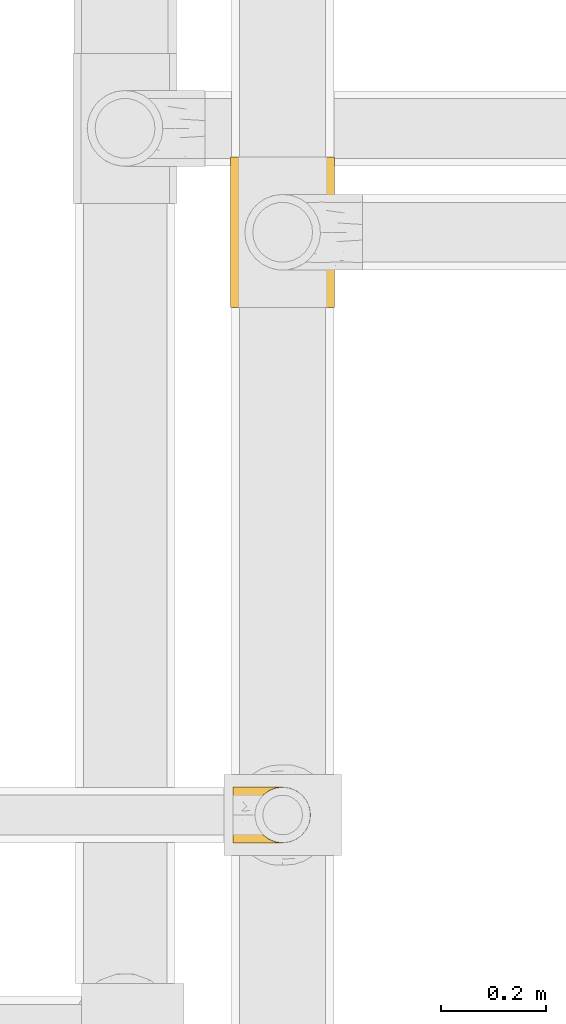
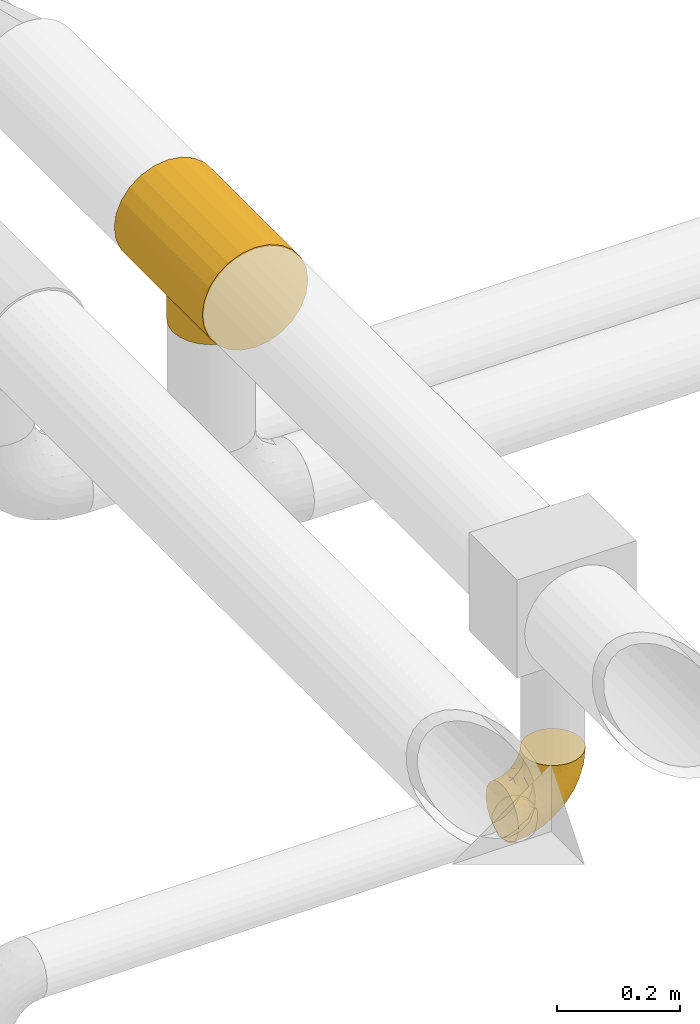
# One storey, part 234 of 827: 2 coverings.
"""IFC2X3 building model written with IfcOpenShell, lengths in millimetres."""

import ifcopenshell
import ifcopenshell.guid

model = None  # the IFC model being written
_history = None  # IfcOwnerHistory: only IFC2X3 demands one
_inside = {}  # id of a spatial element -> (the spatial element, [elements in it])
_under = {}  # id of a project, library or spatial element -> (it, [spatial elements below it])
_declared = {}  # id of a project -> (the project, [libraries it declares])
_typed = {}  # id of a type object -> (the type object, [elements of that type])
_made_of = {}  # id of a material, layer set ... -> (it, [elements and type objects made of it])


def new_model(schema):
    """Start an empty IFC model of exactly this schema.

    Asked for "IFC4X3", IfcOpenShell would pick the latest addendum, in which some entities
    have other attributes; the version numbers below select the first issue.
    IFC2X3 requires an IfcOwnerHistory on every rooted entity: one is made here for all.
    """
    global model, _history
    if schema == "IFC4X3":
        model = ifcopenshell.file(schema_version=(4, 3, 0, 0))
    else:
        model = ifcopenshell.file(schema=schema)
    _inside.clear()
    _under.clear()
    _declared.clear()
    _typed.clear()
    _made_of.clear()
    _history = None
    if model.schema == "IFC2X3":
        org = make("IfcOrganization", Name="unknown")
        user = make(
            "IfcPersonAndOrganization",
            ThePerson=make("IfcPerson", FamilyName="unknown"),
            TheOrganization=org,
        )
        app = make(
            "IfcApplication",
            ApplicationDeveloper=org,
            Version="unknown",
            ApplicationFullName="unknown",
            ApplicationIdentifier="unknown",
        )
        _history = make(
            "IfcOwnerHistory",
            OwningUser=user,
            OwningApplication=app,
            ChangeAction="ADDED",
            CreationDate=0,
        )
    return model


def make(cls, **values):
    """One entity of the class cls with the attributes given. An attribute that is None is left unset."""
    return model.create_entity(
        cls, **{name: value for name, value in values.items() if value is not None}
    )


def entity(cls, *values):
    """Any entity or typed value of the class cls, its attributes in the order of the schema. None: left unset."""
    e = model.create_entity(cls)
    for i, value in enumerate(values):
        if value is not None:
            e[i] = value
    return e


def rooted(cls, **values):
    """An entity with a GlobalId (a new one), such as an element, a storey or a relation."""
    return make(cls, GlobalId=ifcopenshell.guid.new(), OwnerHistory=_history, **values)


def si_unit(unit_type, name, prefix=None):
    """IfcSIUnit, for example si_unit("LENGTHUNIT", "METRE", prefix="MILLI")."""
    return make("IfcSIUnit", UnitType=unit_type, Prefix=prefix, Name=name)


def converted_unit(unit_type, name, factor, base, dimensions=None, offset=None):
    """IfcConversionBasedUnit, such as the inch: factor (a typed value) times the base unit."""
    return make(
        "IfcConversionBasedUnit"
        if offset is None
        else "IfcConversionBasedUnitWithOffset",
        ConversionOffset=offset,
        Dimensions=None
        if dimensions is None
        else entity("IfcDimensionalExponents", *dimensions),
        UnitType=unit_type,
        Name=name,
        ConversionFactor=make(
            "IfcMeasureWithUnit", ValueComponent=factor, UnitComponent=base
        ),
    )


def derived_unit(unit_type, elements):
    """IfcDerivedUnit: a product of units, each with its exponent."""
    return make(
        "IfcDerivedUnit",
        Elements=[
            make("IfcDerivedUnitElement", Unit=unit, Exponent=power)
            for unit, power in elements
        ],
        UnitType=unit_type,
    )


def assignment(units):
    """IfcUnitAssignment: the units of a project."""
    return None if units is None else make("IfcUnitAssignment", Units=units)


def point(xyz):
    """IfcCartesianPoint."""
    return None if xyz is None else make("IfcCartesianPoint", Coordinates=xyz)


def direction(xyz):
    """IfcDirection."""
    return None if xyz is None else make("IfcDirection", DirectionRatios=xyz)


def frame(location, z_axis=None, x_axis=None):
    """IfcAxis2Placement3D, a coordinate frame: its origin and axes. An axis left out is left unset."""
    return make(
        "IfcAxis2Placement3D",
        Location=point(location),
        Axis=direction(z_axis),
        RefDirection=direction(x_axis),
    )


def origin():
    """The frame at (0, 0, 0) with its axes left unset."""
    return frame((0.0, 0.0, 0.0))


def place(relative_to, where):
    """IfcLocalPlacement: puts the frame where relative to a parent placement (None: the world)."""
    return make(
        "IfcLocalPlacement", PlacementRelTo=relative_to, RelativePlacement=where
    )


def context(
    kind, dimensions, precision=None, world=None, true_north=None, identifier=None
):
    """IfcGeometricRepresentationContext, for example the 3D "Model" context."""
    return make(
        "IfcGeometricRepresentationContext",
        ContextIdentifier=identifier,
        ContextType=kind,
        CoordinateSpaceDimension=dimensions,
        Precision=precision,
        WorldCoordinateSystem=world,
        TrueNorth=true_north,
    )


def subcontext(parent, identifier, kind, view, scale=None):
    """IfcGeometricRepresentationSubContext, for example "Body" below "Model"."""
    return make(
        "IfcGeometricRepresentationSubContext",
        ContextIdentifier=identifier,
        ContextType=kind,
        ParentContext=parent,
        TargetScale=scale,
        TargetView=view,
    )


def project(units=None, contexts=None):
    """IfcProject with its units and contexts."""
    return rooted(
        "IfcProject",
        Name="project",
        RepresentationContexts=contexts,
        UnitsInContext=assignment(units),
    )


def spatial(cls, under=None, at=None, **own):
    """A site, building, storey or space (cls), placed at a placement, below another one or the project."""
    s = rooted(cls, ObjectPlacement=at, **own)
    if under is not None:
        _under.setdefault(under.id(), (under, []))[1].append(s)
    return s


def faces_of(points, faces, orient=None, outer=None):
    """IfcFace entities. A face is a list of loops; a loop is a list of indices into points, from 0.

    orient and outer hold one flag for each loop. By default every Orientation is true, the
    first loop of a face is its IfcFaceOuterBound and the others are IfcFaceBound.
    """
    made = []
    for i, loops in enumerate(faces):
        bounds = []
        for j, loop in enumerate(loops):
            is_outer = j == 0 if outer is None else outer[i][j]
            bounds.append(
                make(
                    "IfcFaceOuterBound" if is_outer else "IfcFaceBound",
                    Bound=make("IfcPolyLoop", Polygon=[points[k] for k in loop]),
                    Orientation=True if orient is None else orient[i][j],
                )
            )
        made.append(make("IfcFace", Bounds=bounds))
    return made


def faceted_brep(points, faces, orient=None, outer=None, voids=None):
    """IfcFacetedBrep: a solid bounded by flat faces; with voids (closed shells), ...WithVoids."""
    shared = [point(p) for p in points]
    hull = make("IfcClosedShell", CfsFaces=faces_of(shared, faces, orient, outer))
    if voids is None:
        return make("IfcFacetedBrep", Outer=hull)
    return make(
        "IfcFacetedBrepWithVoids",
        Outer=hull,
        Voids=[
            make(cls, CfsFaces=faces_of(shared, fs, o, b)) for cls, fs, o, b in voids
        ],
    )


def shape(context_of_items, identifier, shape_type, items):
    """IfcShapeRepresentation: the items that make up one representation, for example the "Body"."""
    return make(
        "IfcShapeRepresentation",
        ContextOfItems=context_of_items,
        RepresentationIdentifier=identifier,
        RepresentationType=shape_type,
        Items=items,
    )


def made_of(thing, what):
    """Note that an element or type object is made of a material, layer set ...; save() writes the relation."""
    if what is not None:
        _made_of.setdefault(what.id(), (what, []))[1].append(thing)
    return thing


def element(
    cls,
    number,
    at=None,
    inside=None,
    cuts=None,
    type_object=None,
    material=None,
    context=None,
    identifier="Body",
    shape_type=None,
    held_by="IfcProductDefinitionShape",
    body=None,
    shapes=None,
    **own,
):
    """One element of the class cls, such as IfcWall. Its Tag is "e" and its number.

    at: its placement. inside: the storey or other place that contains it. cuts: it is an
    opening in that element (IfcRelVoidsElement). A single representation is given by context,
    identifier, shape_type and body (its items); several are given by shapes. held_by: the class
    of the entity that holds the representations. save() writes the other relations.
    """
    e = rooted(cls, Tag="e%d" % number, ObjectPlacement=at, **own)
    if body is not None:
        shapes = [shape(context, identifier, shape_type, body)]
    if shapes is not None:
        e.Representation = make(held_by, Representations=shapes)
    if inside is not None:
        _inside.setdefault(inside.id(), (inside, []))[1].append(e)
    if cuts is not None:
        rooted(
            "IfcRelVoidsElement", RelatingBuildingElement=cuts, RelatedOpeningElement=e
        )
    if type_object is not None:
        _typed.setdefault(type_object.id(), (type_object, []))[1].append(e)
    return made_of(e, material)


def aggregate(whole, parts):
    """IfcRelAggregates: a whole, such as a stair, and the parts it consists of."""
    return rooted("IfcRelAggregates", RelatingObject=whole, RelatedObjects=parts)


def save(model, path):
    """Write the relations noted so far, then the file.

    IfcRelAggregates (storeys below a building ...), IfcRelContainedInSpatialStructure (elements
    in a storey), IfcRelDefinesByType, IfcRelAssociatesMaterial and IfcRelDeclares: one each for
    every whole, place, type object, material and project.
    """
    for whole, parts in _under.values():
        aggregate(whole, parts)
    for where, things in _inside.values():
        rooted(
            "IfcRelContainedInSpatialStructure",
            RelatedElements=things,
            RelatingStructure=where,
        )
    for kind, things in _typed.values():
        rooted("IfcRelDefinesByType", RelatedObjects=things, RelatingType=kind)
    for what, things in _made_of.values():
        rooted("IfcRelAssociatesMaterial", RelatedObjects=things, RelatingMaterial=what)
    for by, libraries in _declared.values():
        rooted("IfcRelDeclares", RelatingContext=by, RelatedDefinitions=libraries)
    model.write(path)


model = new_model("IFC2X3")

# Units and contexts
model_context = context("Model", 3, precision=0.01, world=origin(), true_north=direction((6.12303176911189e-17, 1.0)))
body_context = subcontext(model_context, "Body", "Model", "MODEL_VIEW")
ifc_project = project(units=[si_unit("LENGTHUNIT", "METRE", prefix="MILLI"), si_unit("AREAUNIT", "SQUARE_METRE"), si_unit("VOLUMEUNIT", "CUBIC_METRE"), converted_unit("PLANEANGLEUNIT", "DEGREE", entity("IfcRatioMeasure", 0.0174532925199433), si_unit("PLANEANGLEUNIT", "RADIAN"), dimensions=[0, 0, 0, 0, 0, 0, 0]), si_unit("MASSUNIT", "GRAM", prefix="KILO"), derived_unit("MASSDENSITYUNIT", [(si_unit("MASSUNIT", "GRAM", prefix="KILO"), 1), (si_unit("LENGTHUNIT", "METRE"), -3)]), derived_unit("MOMENTOFINERTIAUNIT", [(si_unit("LENGTHUNIT", "METRE"), 4)]), si_unit("TIMEUNIT", "SECOND"), si_unit("FREQUENCYUNIT", "HERTZ"), si_unit("THERMODYNAMICTEMPERATUREUNIT", "DEGREE_CELSIUS"), derived_unit("THERMALTRANSMITTANCEUNIT", [(si_unit("MASSUNIT", "GRAM", prefix="KILO"), 1), (si_unit("THERMODYNAMICTEMPERATUREUNIT", "KELVIN"), -1), (si_unit("TIMEUNIT", "SECOND"), -3)]), derived_unit("VOLUMETRICFLOWRATEUNIT", [(si_unit("LENGTHUNIT", "METRE"), 3), (si_unit("TIMEUNIT", "SECOND"), -1)]), derived_unit("MASSFLOWRATEUNIT", [(si_unit("MASSUNIT", "GRAM", prefix="KILO"), 1), (si_unit("TIMEUNIT", "SECOND"), -1)]), derived_unit("ROTATIONALFREQUENCYUNIT", [(si_unit("TIMEUNIT", "SECOND"), -1)]), si_unit("ELECTRICCURRENTUNIT", "AMPERE"), si_unit("ELECTRICVOLTAGEUNIT", "VOLT"), si_unit("POWERUNIT", "WATT"), si_unit("FORCEUNIT", "NEWTON", prefix="KILO"), si_unit("ILLUMINANCEUNIT", "LUX"), si_unit("LUMINOUSFLUXUNIT", "LUMEN"), si_unit("LUMINOUSINTENSITYUNIT", "CANDELA"), derived_unit("USERDEFINED", [(si_unit("MASSUNIT", "GRAM", prefix="KILO"), -1), (si_unit("LENGTHUNIT", "METRE"), -2), (si_unit("TIMEUNIT", "SECOND"), 3), (si_unit("LUMINOUSFLUXUNIT", "LUMEN"), 1)]), derived_unit("LINEARVELOCITYUNIT", [(si_unit("LENGTHUNIT", "METRE"), 1), (si_unit("TIMEUNIT", "SECOND"), -1)]), si_unit("PRESSUREUNIT", "PASCAL"), derived_unit("USERDEFINED", [(si_unit("LENGTHUNIT", "METRE"), -2), (si_unit("MASSUNIT", "GRAM", prefix="KILO"), 1), (si_unit("TIMEUNIT", "SECOND"), -2)]), derived_unit("LINEARFORCEUNIT", [(si_unit("MASSUNIT", "GRAM", prefix="KILO"), 1), (si_unit("LENGTHUNIT", "METRE"), 1), (si_unit("TIMEUNIT", "SECOND"), -2), (si_unit("LENGTHUNIT", "METRE"), -1)]), derived_unit("PLANARFORCEUNIT", [(si_unit("MASSUNIT", "GRAM", prefix="KILO"), 1), (si_unit("LENGTHUNIT", "METRE"), 1), (si_unit("TIMEUNIT", "SECOND"), -2), (si_unit("LENGTHUNIT", "METRE"), -2)])], contexts=[model_context])

# Site, building, storey
site_placement = place(None, origin())
site = spatial("IfcSite", under=ifc_project, at=site_placement, CompositionType="ELEMENT")
building_placement = place(site_placement, origin())
building = spatial("IfcBuilding", under=site, at=building_placement, CompositionType="ELEMENT")
storey_placement = place(building_placement, frame((0.0, 0.0, 28200.0)))
storey = spatial("IfcBuildingStorey", under=building, at=storey_placement, Name="08", CompositionType="ELEMENT", Elevation=28200.0)

# Coverings
covering_1_placement = place(storey_placement, frame((37951.7, 12925.0, 2545.35)))
element("IfcCovering", 1, at=covering_1_placement, inside=storey, Name=":ADSK_", ObjectType=":ADSK_", PredefinedType="INSULATION", context=body_context, shape_type="Brep", body=[
    faceted_brep([(1.6, 66.44, 2.92), (1.6, 54.65, 1.6), (1.6, 42.84, 2.93), (1.6, 31.62, 6.85), (1.6, 21.56, 13.18), (1.6, 13.16, 21.58), (1.6, 6.84, 31.64), (1.6, 2.92, 42.85), (1.6, 1.6, 54.65), (1.6, 2.93, 66.46), (1.6, 6.85, 77.67), (1.6, 13.18, 87.73), (1.6, 21.58, 96.13), (1.6, 31.64, 102.45), (1.6, 42.85, 106.37), (1.6, 54.65, 107.7), (1.6, 66.46, 106.36), (1.6, 77.67, 102.44), (1.6, 87.73, 96.11), (1.6, 96.13, 87.71), (1.6, 102.45, 77.65), (1.6, 106.37, 66.44), (1.6, 107.7, 54.65), (1.6, 106.36, 42.84), (1.6, 102.44, 31.62), (1.6, 96.11, 21.56), (1.6, 87.71, 13.16), (1.6, 77.65, 6.84), (45.35, 40.91, 149.65), (50.65, 28.12, 149.65), (59.08, 17.13, 149.65), (70.07, 8.7, 149.65), (82.86, 3.4, 149.65), (96.6, 1.6, 149.65), (110.33, 3.4, 149.65), (123.12, 8.7, 149.65), (134.11, 17.13, 149.65), (142.54, 28.12, 149.65), (147.84, 40.91, 149.65), (149.65, 54.65, 149.65), (147.84, 68.38, 149.65), (142.54, 81.17, 149.65), (134.11, 92.16, 149.65), (123.12, 100.59, 149.65), (110.33, 105.89, 149.65), (96.6, 107.7, 149.65), (82.86, 105.89, 149.65), (70.07, 100.59, 149.65), (59.08, 92.16, 149.65), (50.65, 81.17, 149.65), (45.35, 68.38, 149.65), (43.55, 54.65, 149.65), (137.19, 85.53, 123.27), (141.79, 73.42, 114.15), (128.89, 83.77, 92.97), (146.54, 64.22, 124.11), (144.6, 54.65, 111.33), (69.77, 96.72, 42.13), (94.41, 93.36, 56.83), (87.22, 84.47, 40.31), (117.2, 71.37, 61.55), (129.81, 54.65, 75.62), (106.28, 54.65, 44.96), (101.45, 103.47, 91.12), (115.81, 100.91, 109.83), (109.14, 99.1, 88.02), (107.65, 105.43, 119.19), (93.36, 106.79, 99.11), (59.44, 89.81, 27.97), (63.23, 79.59, 21.92), (35.59, 81.29, 12.94), (132.3, 74.01, 88.29), (138.41, 64.14, 95.35), (126.28, 94.75, 113.84), (39.91, 54.65, 6.64), (37.44, 70.74, 8.58), (90.35, 68.3, 33.39), (65.0, 66.05, 17.23), (85.4, 100.73, 61.99), (26.66, 106.78, 47.9), (29.88, 103.6, 37.72), (78.45, 107.7, 93.81), (85.2, 107.7, 107.05), (91.95, 107.7, 120.29), (77.98, 106.07, 73.26), (29.55, 90.59, 18.58), (41.42, 97.43, 29.72), (111.13, 84.51, 64.31), (114.67, 93.3, 82.84), (57.43, 107.7, 72.79), (67.94, 107.7, 83.3), (14.64, 107.7, 56.71), (30.95, 107.7, 59.29), (52.13, 106.79, 57.88), (44.19, 107.7, 66.04), (60.12, 103.47, 49.8), (75.62, 54.65, 21.43), (94.27, 107.7, 134.97), (24.59, 76.99, 108.79), (34.69, 84.28, 110.84), (31.15, 91.11, 101.53), (75.18, 106.26, 111.84), (67.55, 102.6, 119.98), (79.36, 106.08, 123.54), (84.32, 106.56, 134.54), (40.81, 105.36, 80.57), (29.93, 106.74, 69.55), (70.24, 101.59, 134.56), (37.93, 54.65, 128.67), (40.15, 54.65, 136.98), (42.1, 67.71, 133.56), (55.38, 91.36, 131.66), (52.17, 94.33, 117.75), (44.32, 87.1, 118.23), (19.85, 65.84, 110.55), (14.26, 54.65, 111.09), (22.57, 54.65, 113.32), (34.17, 68.92, 120.2), (54.85, 100.82, 105.95), (44.63, 79.83, 127.69), (47.52, 77.13, 139.88), (59.1, 105.9, 92.14), (44.11, 101.53, 93.82), (53.21, 106.72, 82.28), (62.86, 97.75, 130.86), (20.58, 103.08, 78.78), (15.79, 106.39, 67.58), (27.67, 98.1, 90.58), (13.49, 95.02, 90.23), (18.04, 86.9, 99.39), (12.44, 74.42, 105.17), (30.25, 54.65, 120.99), (66.71, 105.28, 104.59), (42.52, 92.87, 108.24), (55.38, 17.93, 131.66), (20.57, 6.22, 78.8), (42.11, 41.58, 133.57), (57.43, 1.6, 72.79), (53.22, 2.57, 82.27), (40.81, 3.94, 80.59), (19.85, 43.46, 110.55), (24.58, 32.32, 108.79), (34.16, 40.38, 120.2), (42.5, 16.44, 108.25), (54.93, 8.47, 106.06), (52.13, 15.01, 117.78), (27.66, 11.21, 90.6), (44.12, 7.78, 93.87), (78.45, 1.6, 93.81), (85.2, 1.6, 107.05), (75.17, 3.04, 111.89), (94.27, 1.6, 134.97), (84.32, 2.73, 134.54), (30.95, 1.6, 59.29), (44.19, 1.6, 66.04), (29.98, 2.55, 69.56), (66.78, 3.98, 104.56), (67.55, 6.69, 119.98), (70.24, 7.7, 134.56), (79.36, 3.21, 123.54), (13.48, 14.28, 90.25), (18.03, 22.42, 99.4), (34.66, 25.02, 110.83), (31.14, 18.18, 101.52), (12.43, 34.89, 105.18), (14.64, 1.6, 56.71), (47.52, 32.17, 139.89), (44.28, 22.23, 118.22), (15.8, 2.91, 67.6), (62.86, 11.54, 130.86), (67.94, 1.6, 83.3), (59.12, 3.38, 92.12), (44.64, 29.46, 127.71), (91.95, 1.6, 120.29), (128.89, 25.52, 92.97), (137.19, 23.76, 123.27), (126.28, 14.54, 113.84), (115.81, 8.38, 109.83), (146.53, 45.07, 124.03), (141.79, 35.87, 114.15), (139.45, 45.14, 98.04), (93.36, 2.5, 99.11), (26.67, 2.51, 47.9), (29.87, 5.68, 37.74), (60.12, 5.82, 49.8), (94.41, 15.93, 56.83), (69.76, 12.54, 42.16), (87.19, 24.81, 40.3), (52.13, 2.5, 57.88), (77.98, 3.22, 73.26), (107.65, 3.86, 119.19), (131.74, 35.85, 86.61), (59.44, 19.47, 27.99), (29.54, 18.68, 18.59), (63.2, 29.68, 21.92), (27.9, 27.95, 11.28), (90.35, 40.99, 33.39), (117.2, 37.92, 61.55), (41.39, 11.85, 29.73), (109.14, 10.19, 88.01), (85.46, 8.55, 62.08), (37.43, 38.53, 8.58), (114.67, 15.99, 82.84), (111.12, 24.79, 64.3), (101.45, 5.82, 91.12), (65.16, 40.56, 18.05)], [[[0, 1, 2, 3, 4, 5, 6, 7, 8, 9, 10, 11, 12, 13, 14, 15, 16, 17, 18, 19, 20, 21, 22, 23, 24, 25, 26, 27]], [[28, 29, 30, 31, 32, 33, 34, 35, 36, 37, 38, 39, 40, 41, 42, 43, 44, 45, 46, 47, 48, 49, 50, 51]], [[52, 53, 54]], [[55, 39, 56]], [[57, 58, 59]], [[60, 61, 62]], [[63, 64, 65]], [[66, 63, 67]], [[68, 69, 70]], [[53, 71, 54]], [[41, 40, 53]], [[53, 72, 71]], [[73, 42, 52]], [[42, 41, 52]], [[74, 0, 75]], [[69, 76, 77]], [[43, 73, 64]], [[45, 44, 66]], [[57, 78, 58]], [[23, 79, 80]], [[67, 81, 82, 83]], [[67, 84, 81]], [[24, 23, 80]], [[25, 85, 26]], [[86, 85, 25]], [[42, 73, 43]], [[0, 27, 75]], [[25, 24, 86]], [[70, 26, 85]], [[0, 74, 1]], [[68, 85, 86]], [[66, 64, 63]], [[60, 59, 87]], [[54, 87, 88]], [[76, 60, 62]], [[84, 89, 90, 81]], [[79, 22, 91, 92]], [[77, 74, 75]], [[93, 92, 94, 89]], [[80, 86, 24]], [[40, 55, 53]], [[76, 59, 60]], [[93, 84, 95]], [[76, 62, 96]], [[55, 72, 53]], [[70, 27, 26]], [[75, 70, 69]], [[78, 84, 63]], [[93, 79, 92]], [[95, 86, 80]], [[77, 76, 96]], [[59, 69, 68]], [[57, 68, 86]], [[68, 57, 59]], [[59, 58, 87]], [[76, 69, 59]], [[88, 87, 58]], [[87, 54, 71]], [[86, 95, 57]], [[78, 57, 95]], [[84, 78, 95]], [[78, 63, 65]], [[58, 78, 65]], [[54, 88, 73]], [[84, 93, 89]], [[79, 95, 80]], [[79, 93, 95]], [[22, 79, 23]], [[66, 83, 97, 45]], [[84, 67, 63]], [[83, 66, 67]], [[64, 44, 43]], [[64, 66, 44]], [[65, 73, 88]], [[53, 52, 41]], [[73, 52, 54]], [[73, 65, 64]], [[65, 88, 58]], [[39, 55, 40]], [[72, 55, 56]], [[56, 61, 72]], [[60, 72, 61]], [[72, 60, 71]], [[87, 71, 60]], [[27, 70, 75]], [[68, 70, 85]], [[74, 77, 96]], [[69, 77, 75]], [[98, 99, 100]], [[46, 45, 97]], [[101, 102, 103]], [[103, 104, 83]], [[105, 94, 106]], [[107, 103, 102]], [[108, 109, 51, 110]], [[111, 112, 113]], [[114, 115, 116]], [[47, 104, 107]], [[110, 117, 108]], [[49, 48, 111]], [[102, 118, 112]], [[119, 120, 111]], [[50, 49, 120]], [[121, 122, 118]], [[105, 123, 89]], [[124, 48, 107]], [[20, 19, 125]], [[121, 81, 90]], [[117, 119, 99]], [[21, 20, 126]], [[22, 21, 91]], [[105, 125, 127]], [[110, 51, 50]], [[19, 128, 125]], [[16, 15, 115]], [[129, 98, 100]], [[126, 91, 21]], [[128, 129, 127]], [[122, 123, 105]], [[114, 117, 98]], [[17, 16, 130]], [[18, 128, 19]], [[129, 18, 17]], [[125, 106, 126]], [[115, 114, 16]], [[130, 129, 17]], [[114, 98, 130]], [[117, 116, 131, 108]], [[99, 119, 113]], [[122, 121, 123]], [[92, 126, 106]], [[105, 127, 122]], [[132, 121, 118]], [[114, 130, 16]], [[129, 130, 98]], [[50, 120, 110]], [[129, 128, 18]], [[125, 128, 127]], [[125, 126, 20]], [[91, 126, 92]], [[105, 89, 94]], [[105, 106, 125]], [[94, 92, 106]], [[100, 122, 127]], [[118, 122, 133]], [[112, 118, 133]], [[132, 118, 102]], [[132, 102, 101]], [[81, 121, 132]], [[82, 103, 83]], [[132, 101, 81]], [[104, 47, 46]], [[124, 107, 102]], [[48, 47, 107]], [[113, 112, 133]], [[112, 111, 124]], [[99, 113, 133]], [[111, 113, 119]], [[99, 133, 100]], [[117, 99, 98]], [[122, 100, 133]], [[127, 129, 100]], [[103, 82, 101]], [[81, 101, 82]], [[112, 124, 102]], [[48, 124, 111]], [[104, 103, 107]], [[46, 97, 104]], [[111, 120, 49]], [[83, 104, 97]], [[110, 120, 119]], [[117, 110, 119]], [[116, 117, 114]], [[89, 123, 90]], [[90, 123, 121]], [[30, 29, 134]], [[11, 10, 135]], [[51, 109, 108, 136]], [[137, 138, 139]], [[140, 141, 142]], [[143, 144, 145]], [[146, 139, 147]], [[148, 149, 150]], [[151, 32, 152]], [[153, 154, 155]], [[156, 150, 157]], [[158, 157, 159]], [[108, 142, 136]], [[31, 158, 152]], [[160, 161, 12]], [[162, 163, 143]], [[140, 142, 116]], [[142, 141, 162]], [[14, 164, 140]], [[14, 140, 115]], [[9, 8, 165]], [[160, 12, 11]], [[141, 164, 161]], [[13, 12, 161]], [[14, 115, 15]], [[28, 166, 29]], [[135, 139, 146]], [[141, 163, 162]], [[135, 146, 160]], [[143, 167, 162]], [[29, 166, 134]], [[116, 142, 108, 131]], [[165, 153, 168]], [[10, 9, 168]], [[168, 135, 10]], [[138, 147, 139]], [[158, 169, 157]], [[14, 13, 164]], [[116, 115, 140]], [[145, 167, 143]], [[135, 160, 11]], [[168, 153, 155]], [[138, 170, 171]], [[157, 144, 156]], [[147, 144, 143]], [[161, 164, 13]], [[140, 164, 141]], [[142, 172, 136]], [[136, 172, 166]], [[161, 160, 146]], [[165, 168, 9]], [[155, 139, 135]], [[139, 154, 137]], [[168, 155, 135]], [[139, 155, 154]], [[144, 147, 171]], [[163, 147, 143]], [[156, 144, 171]], [[157, 169, 145]], [[171, 148, 156]], [[173, 159, 149]], [[159, 157, 150]], [[152, 159, 173]], [[159, 152, 158]], [[31, 30, 158]], [[169, 30, 134]], [[157, 145, 144]], [[167, 134, 172]], [[134, 167, 145]], [[172, 142, 162]], [[162, 167, 172]], [[163, 141, 161]], [[161, 146, 163]], [[147, 163, 146]], [[148, 150, 156]], [[149, 159, 150]], [[30, 169, 158]], [[145, 169, 134]], [[151, 33, 32]], [[31, 152, 32]], [[152, 173, 151]], [[28, 51, 136]], [[134, 166, 172]], [[28, 136, 166]], [[147, 138, 171]], [[170, 138, 137]], [[170, 148, 171]], [[174, 175, 176]], [[35, 34, 177]], [[178, 179, 180]], [[181, 173, 149, 148]], [[182, 183, 184]], [[185, 186, 187]], [[188, 189, 137]], [[190, 33, 151, 173]], [[191, 179, 174]], [[34, 190, 177]], [[39, 38, 178]], [[192, 193, 194]], [[4, 3, 195]], [[175, 179, 37]], [[38, 37, 179]], [[35, 176, 36]], [[196, 62, 197]], [[181, 190, 173]], [[37, 36, 175]], [[183, 6, 198]], [[189, 148, 170, 137]], [[185, 199, 200]], [[3, 2, 201]], [[202, 185, 203]], [[8, 7, 182]], [[200, 184, 186]], [[183, 7, 6]], [[181, 189, 204]], [[200, 189, 184]], [[5, 198, 6]], [[187, 203, 185]], [[195, 3, 201]], [[205, 196, 194]], [[62, 61, 197]], [[186, 198, 192]], [[180, 179, 191]], [[2, 1, 74]], [[198, 193, 192]], [[193, 5, 4]], [[194, 193, 195]], [[2, 74, 201]], [[5, 193, 198]], [[205, 74, 96]], [[188, 137, 154, 153]], [[62, 196, 96]], [[56, 178, 180]], [[198, 184, 183]], [[184, 188, 182]], [[203, 197, 191]], [[205, 194, 201]], [[187, 192, 194]], [[192, 187, 186]], [[194, 196, 187]], [[197, 187, 196]], [[197, 203, 187]], [[202, 174, 176]], [[200, 186, 185]], [[184, 198, 186]], [[199, 185, 202]], [[189, 200, 204]], [[174, 202, 203]], [[176, 177, 199]], [[189, 181, 148]], [[190, 181, 204]], [[190, 204, 177]], [[190, 34, 33]], [[188, 153, 182]], [[189, 188, 184]], [[182, 153, 165, 8]], [[183, 182, 7]], [[199, 177, 204]], [[35, 177, 176]], [[176, 175, 36]], [[179, 175, 174]], [[200, 199, 204]], [[176, 199, 202]], [[203, 191, 174]], [[180, 197, 61]], [[197, 180, 191]], [[61, 56, 180]], [[39, 178, 56]], [[38, 179, 178]], [[194, 195, 201]], [[4, 195, 193]], [[74, 205, 201]], [[96, 196, 205]]]),
])
covering_2_placement = place(storey_placement, frame((37947.55, 13945.91, 2870.0)))
element("IfcCovering", 2, at=covering_2_placement, inside=storey, Name=":ADSK_", ObjectType=":ADSK_", PredefinedType="INSULATION", context=body_context, shape_type="Brep", body=[
    faceted_brep([(4.97, 286.0, 155.66), (14.88, 286.0, 179.57), (30.64, 286.0, 200.11), (51.17, 286.0, 215.87), (75.08, 286.0, 225.77), (100.75, 286.0, 229.15), (126.41, 286.0, 225.77), (150.32, 286.0, 215.87), (170.85, 286.0, 200.11), (186.61, 286.0, 179.57), (196.52, 286.0, 155.66), (199.9, 286.0, 130.0), (196.52, 286.0, 104.34), (186.61, 286.0, 80.42), (170.85, 286.0, 59.89), (150.32, 286.0, 44.13), (138.36, 286.0, 39.18), (126.41, 286.0, 34.23), (113.58, 286.0, 32.54), (100.75, 286.0, 30.85), (87.91, 286.0, 32.54), (75.08, 286.0, 34.23), (63.13, 286.0, 39.18), (51.17, 286.0, 44.13), (30.64, 286.0, 59.89), (14.88, 286.0, 80.42), (4.97, 286.0, 104.34), (1.6, 286.0, 130.0), (199.9, 0.0, 130.0), (196.52, 0.0, 155.66), (186.61, 0.0, 179.57), (170.85, 0.0, 200.11), (150.32, 0.0, 215.87), (126.41, 0.0, 225.77), (100.75, 0.0, 229.15), (75.08, 0.0, 225.77), (51.17, 0.0, 215.87), (30.64, 0.0, 200.11), (14.88, 0.0, 179.57), (4.97, 0.0, 155.66), (1.6, 0.0, 130.0), (4.97, 0.0, 104.34), (14.88, 0.0, 80.42), (30.64, 0.0, 59.89), (51.17, 0.0, 44.13), (63.13, 0.0, 39.18), (75.08, 0.0, 34.23), (87.91, 0.0, 32.54), (100.75, 0.0, 30.85), (113.58, 0.0, 32.54), (126.41, 0.0, 34.23), (138.36, 0.0, 39.18), (150.32, 0.0, 44.13), (170.85, 0.0, 59.89), (186.61, 0.0, 80.42), (196.52, 0.0, 104.34), (171.71, 129.98, 60.76), (172.9, 143.0, 61.99), (163.04, 106.6, 52.86), (156.09, 96.71, 47.73), (113.8, 72.04, 31.71), (168.32, 117.72, 57.45), (137.58, 205.04, 37.95), (171.71, 156.02, 60.76), (168.32, 168.28, 57.45), (100.75, 215.15, 30.85), (113.8, 213.96, 31.71), (163.04, 179.4, 52.86), (147.57, 88.11, 42.6), (137.58, 80.96, 37.95), (126.23, 75.5, 34.18), (100.75, 70.85, 30.85), (156.09, 189.29, 47.73), (147.57, 197.89, 42.6), (126.23, 210.5, 34.18), (75.26, 75.5, 34.18), (87.69, 72.04, 31.71), (53.92, 88.11, 42.6), (63.91, 80.96, 37.95), (87.69, 213.96, 31.71), (75.26, 210.5, 34.18), (53.92, 197.89, 42.6), (63.91, 205.04, 37.95), (45.4, 189.29, 47.73), (45.4, 96.71, 47.73), (38.45, 106.6, 52.86), (33.17, 117.72, 57.45), (29.78, 129.98, 60.76), (28.6, 143.0, 61.99), (38.45, 179.4, 52.86), (33.17, 168.28, 57.45), (29.78, 156.02, 60.76), (172.9, 143.0, 0.0), (170.44, 124.33, 0.0), (163.23, 106.92, 0.0), (151.76, 91.98, 0.0), (136.82, 80.52, 0.0), (119.42, 73.31, 0.0), (100.75, 70.85, 0.0), (82.07, 73.31, 0.0), (64.67, 80.52, 0.0), (49.73, 91.98, 0.0), (38.26, 106.92, 0.0), (31.05, 124.33, 0.0), (28.6, 143.0, 0.0), (31.05, 161.67, 0.0), (38.26, 179.07, 0.0), (49.73, 194.02, 0.0), (64.67, 205.48, 0.0), (82.07, 212.69, 0.0), (100.75, 215.15, 0.0), (119.42, 212.69, 0.0), (136.82, 205.48, 0.0), (151.76, 194.02, 0.0), (163.23, 179.07, 0.0), (170.44, 161.67, 0.0)], [[[0, 1, 2, 3, 4, 5, 6, 7, 8, 9, 10, 11, 12, 13, 14, 15, 16, 17, 18, 19, 20, 21, 22, 23, 24, 25, 26, 27]], [[28, 29, 30, 31, 32, 33, 34, 35, 36, 37, 38, 39, 40, 41, 42, 43, 44, 45, 46, 47, 48, 49, 50, 51, 52, 53, 54, 55]], [[7, 32, 31, 8]], [[5, 34, 33, 6]], [[6, 33, 32, 7]], [[9, 30, 29, 10]], [[10, 29, 28, 11]], [[8, 31, 30, 9]], [[12, 55, 54, 13]], [[53, 56, 57]], [[55, 12, 11, 28]], [[57, 54, 53]], [[58, 52, 59]], [[52, 58, 53]], [[60, 50, 49]], [[58, 61, 53]], [[62, 17, 16]], [[53, 61, 56]], [[54, 57, 13]], [[57, 14, 13]], [[63, 64, 14]], [[65, 18, 66]], [[15, 14, 67]], [[67, 14, 64]], [[68, 51, 69]], [[63, 14, 57]], [[51, 50, 69]], [[68, 52, 51]], [[50, 70, 69]], [[71, 60, 49]], [[70, 50, 60]], [[49, 48, 71]], [[18, 65, 19]], [[72, 73, 15]], [[73, 16, 15]], [[16, 73, 62]], [[72, 15, 67]], [[74, 66, 17]], [[66, 18, 17]], [[74, 17, 62]], [[68, 59, 52]], [[48, 47, 71]], [[65, 20, 19]], [[46, 75, 76]], [[76, 47, 46]], [[44, 77, 45]], [[78, 45, 77]], [[46, 78, 75]], [[65, 79, 20]], [[79, 80, 21]], [[81, 23, 22]], [[22, 21, 82]], [[23, 81, 83]], [[82, 21, 80]], [[84, 77, 44]], [[44, 85, 84]], [[85, 44, 43]], [[86, 85, 43]], [[43, 87, 86]], [[25, 42, 41, 26]], [[42, 88, 43]], [[43, 88, 87]], [[41, 40, 27, 26]], [[71, 47, 76]], [[89, 90, 24]], [[78, 46, 45]], [[89, 23, 83]], [[23, 89, 24]], [[90, 91, 24]], [[88, 25, 24]], [[79, 21, 20]], [[42, 25, 88]], [[88, 24, 91]], [[81, 22, 82]], [[0, 39, 38, 1]], [[1, 38, 37, 2]], [[40, 39, 0, 27]], [[3, 36, 35, 4]], [[4, 35, 34, 5]], [[2, 37, 36, 3]], [[92, 93, 94, 95, 96, 97, 98, 99, 100, 101, 102, 103, 104, 105, 106, 107, 108, 109, 110, 111, 112, 113, 114, 115]], [[60, 71, 98]], [[60, 98, 97]], [[70, 97, 96]], [[70, 60, 97]], [[68, 69, 96]], [[70, 96, 69]], [[96, 95, 68]], [[59, 95, 94]], [[61, 94, 93]], [[56, 93, 92]], [[59, 94, 58]], [[93, 56, 61]], [[61, 58, 94]], [[56, 92, 57]], [[95, 59, 68]], [[63, 92, 115]], [[115, 114, 64]], [[72, 114, 113]], [[72, 67, 114]], [[57, 92, 63]], [[63, 115, 64]], [[114, 67, 64]], [[73, 113, 112]], [[74, 112, 111]], [[66, 111, 110]], [[62, 73, 112]], [[66, 74, 111]], [[65, 66, 110]], [[62, 112, 74]], [[113, 73, 72]], [[79, 65, 110]], [[79, 110, 109]], [[80, 109, 108]], [[80, 79, 109]], [[81, 82, 108]], [[80, 108, 82]], [[108, 107, 81]], [[83, 107, 106]], [[90, 106, 105]], [[91, 105, 104]], [[83, 106, 89]], [[105, 91, 90]], [[90, 89, 106]], [[91, 104, 88]], [[107, 83, 81]], [[87, 104, 103]], [[103, 102, 86]], [[84, 102, 101]], [[84, 85, 102]], [[88, 104, 87]], [[87, 103, 86]], [[102, 85, 86]], [[77, 101, 100]], [[75, 100, 99]], [[76, 99, 98]], [[78, 77, 100]], [[76, 75, 99]], [[71, 76, 98]], [[78, 100, 75]], [[101, 77, 84]]]),
])

save(model, "model.ifc")
